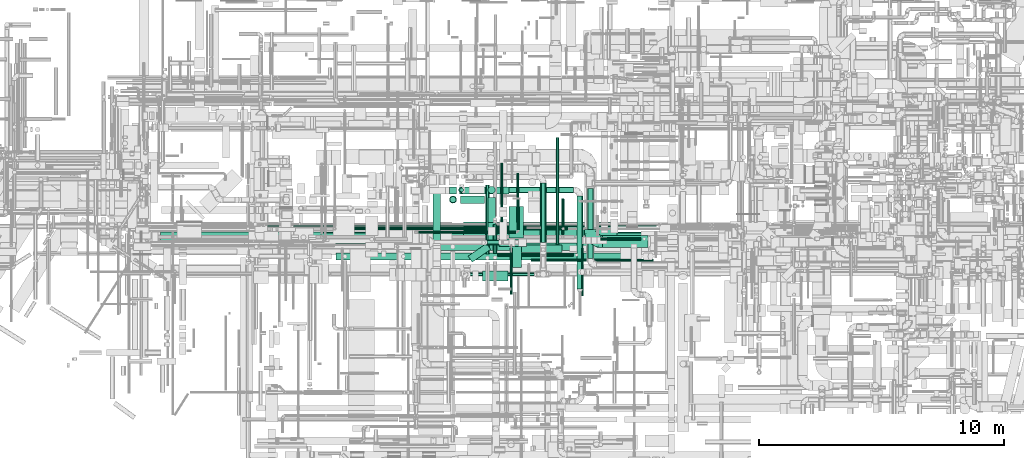
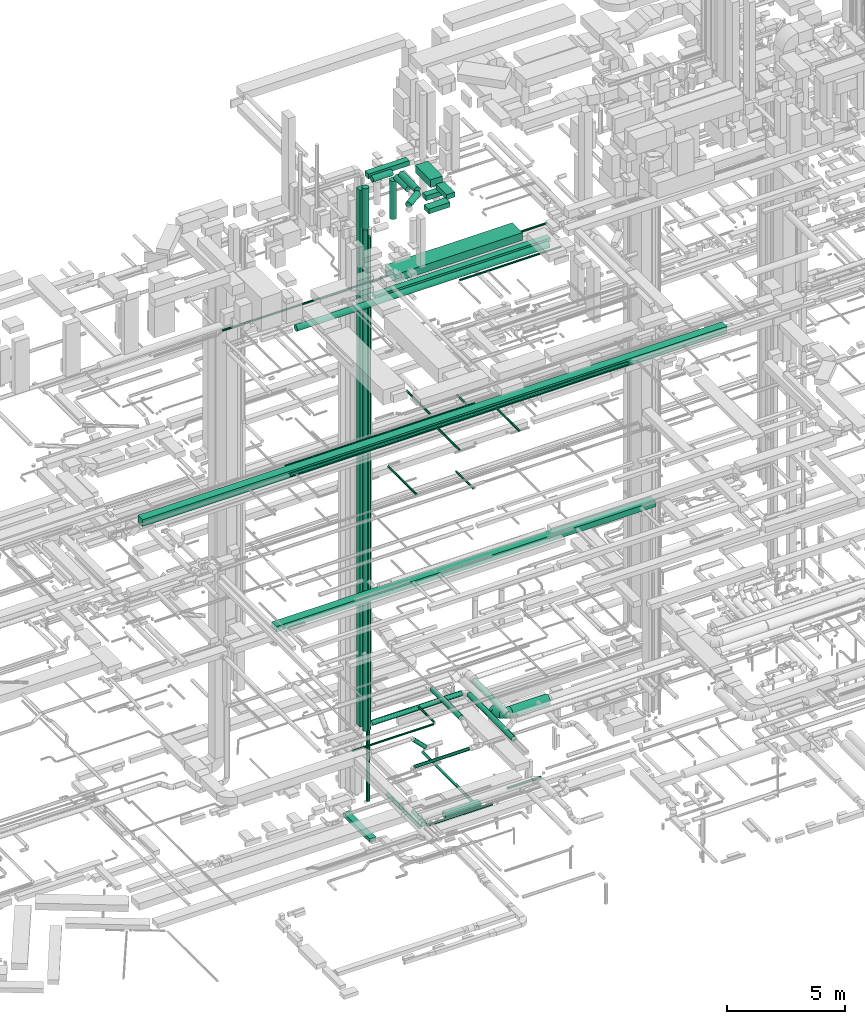
# One storey, part 33 of 337: 46 flow segments, 1 flow fitting.
"""IFC2X3 building model written with IfcOpenShell, lengths in millimetres."""

from ifc_helpers import new_model, entity, si_unit, converted_unit, derived_unit, direction, frame, origin, origin_2d_with_axis, place, context, subcontext, project, spatial, rectangle, circle, extrude, faceted_brep, source, transform, mapped, material, type_object, type_shapes, element, save


model = new_model("IFC2X3")

# Units and contexts
model_context = context("Model", 3, precision=0.01, world=origin(), true_north=direction((6.12303176911189e-17, 1.0)))
body_context = subcontext(model_context, "Body", "Model", "MODEL_VIEW")
ifc_project = project(units=[si_unit("LENGTHUNIT", "METRE", prefix="MILLI"), si_unit("AREAUNIT", "SQUARE_METRE"), si_unit("VOLUMEUNIT", "CUBIC_METRE"), converted_unit("PLANEANGLEUNIT", "DEGREE", entity("IfcRatioMeasure", 0.0174532925199433), si_unit("PLANEANGLEUNIT", "RADIAN"), dimensions=[0, 0, 0, 0, 0, 0, 0]), si_unit("MASSUNIT", "GRAM", prefix="KILO"), derived_unit("MASSDENSITYUNIT", [(si_unit("MASSUNIT", "GRAM", prefix="KILO"), 1), (si_unit("LENGTHUNIT", "METRE"), -3)]), derived_unit("MOMENTOFINERTIAUNIT", [(si_unit("LENGTHUNIT", "METRE"), 4)]), si_unit("TIMEUNIT", "SECOND"), si_unit("FREQUENCYUNIT", "HERTZ"), si_unit("THERMODYNAMICTEMPERATUREUNIT", "DEGREE_CELSIUS"), derived_unit("THERMALTRANSMITTANCEUNIT", [(si_unit("MASSUNIT", "GRAM", prefix="KILO"), 1), (si_unit("THERMODYNAMICTEMPERATUREUNIT", "KELVIN"), -1), (si_unit("TIMEUNIT", "SECOND"), -3)]), derived_unit("VOLUMETRICFLOWRATEUNIT", [(si_unit("LENGTHUNIT", "METRE"), 3), (si_unit("TIMEUNIT", "SECOND"), -1)]), derived_unit("MASSFLOWRATEUNIT", [(si_unit("MASSUNIT", "GRAM", prefix="KILO"), 1), (si_unit("TIMEUNIT", "SECOND"), -1)]), derived_unit("ROTATIONALFREQUENCYUNIT", [(si_unit("TIMEUNIT", "SECOND"), -1)]), si_unit("ELECTRICCURRENTUNIT", "AMPERE"), si_unit("ELECTRICVOLTAGEUNIT", "VOLT"), si_unit("POWERUNIT", "WATT"), si_unit("FORCEUNIT", "NEWTON", prefix="KILO"), si_unit("ILLUMINANCEUNIT", "LUX"), si_unit("LUMINOUSFLUXUNIT", "LUMEN"), si_unit("LUMINOUSINTENSITYUNIT", "CANDELA"), derived_unit("USERDEFINED", [(si_unit("MASSUNIT", "GRAM", prefix="KILO"), -1), (si_unit("LENGTHUNIT", "METRE"), -2), (si_unit("TIMEUNIT", "SECOND"), 3), (si_unit("LUMINOUSFLUXUNIT", "LUMEN"), 1)]), derived_unit("LINEARVELOCITYUNIT", [(si_unit("LENGTHUNIT", "METRE"), 1), (si_unit("TIMEUNIT", "SECOND"), -1)]), si_unit("PRESSUREUNIT", "PASCAL"), derived_unit("USERDEFINED", [(si_unit("LENGTHUNIT", "METRE"), -2), (si_unit("MASSUNIT", "GRAM", prefix="KILO"), 1), (si_unit("TIMEUNIT", "SECOND"), -2)]), derived_unit("LINEARFORCEUNIT", [(si_unit("MASSUNIT", "GRAM", prefix="KILO"), 1), (si_unit("LENGTHUNIT", "METRE"), 1), (si_unit("TIMEUNIT", "SECOND"), -2), (si_unit("LENGTHUNIT", "METRE"), -1)]), derived_unit("PLANARFORCEUNIT", [(si_unit("MASSUNIT", "GRAM", prefix="KILO"), 1), (si_unit("LENGTHUNIT", "METRE"), 1), (si_unit("TIMEUNIT", "SECOND"), -2), (si_unit("LENGTHUNIT", "METRE"), -2)])], contexts=[model_context])

# Site, building, storey
site_placement = place(None, origin())
site = spatial("IfcSite", under=ifc_project, at=site_placement, CompositionType="ELEMENT")
building_placement = place(site_placement, origin())
building = spatial("IfcBuilding", under=site, at=building_placement, CompositionType="ELEMENT")
storey_placement = place(building_placement, origin())
storey = spatial("IfcBuildingStorey", under=building, at=storey_placement, CompositionType="ELEMENT", Elevation=0.0)

# Flow segments
duct_segment_type_1 = type_object("IfcDuctSegmentType", PredefinedType="NOTDEFINED")
flow_segment_1_placement = place(storey_placement, frame((33827.72, 9095.01, -1025.0)))
element("IfcFlowSegment", 1, at=flow_segment_1_placement, inside=storey, type_object=duct_segment_type_1, context=body_context, shape_type="SweptSolid", body=[
    extrude(rectangle(XDim=1760.00000000005, YDim=300.0, at=origin_2d_with_axis()), frame((880.0, 150.0, 0.0), z_axis=(0.0, 0.0, 1.0), x_axis=(-1.0, 0.0, 0.0)), (0.0, 0.0, 1.0), 250.0),
])
flow_segment_2_placement = place(storey_placement, frame((30327.78, 9463.6, -1250.0)))
element("IfcFlowSegment", 2, at=flow_segment_2_placement, inside=storey, type_object=duct_segment_type_1, context=body_context, shape_type="SweptSolid", body=[
    extrude(rectangle(XDim=2274.44161305387, YDim=300.000000000001, at=origin_2d_with_axis()), frame((150.0, 1137.22, 0.0), z_axis=(0.0, 0.0, 1.0), x_axis=(0.0, -1.0, 0.0)), (0.0, 0.0, 1.0), 200.0),
])
flow_segment_3_placement = place(storey_placement, frame((25757.3, 9490.54, 11250.0)))
element("IfcFlowSegment", 3, at=flow_segment_3_placement, inside=storey, type_object=duct_segment_type_1, context=body_context, shape_type="SweptSolid", body=[
    extrude(rectangle(XDim=18609.9999999999, YDim=400.0, at=origin_2d_with_axis()), frame((9305.0, 200.0, 0.0), z_axis=(0.0, 0.0, 1.0), x_axis=(-1.0, 0.0, 0.0)), (0.0, 0.0, 1.0), 300.000000000001),
])
flow_segment_4_placement = place(storey_placement, frame((30990.08, 11464.96, 3300.0)))
element("IfcFlowSegment", 4, at=flow_segment_4_placement, inside=storey, type_object=duct_segment_type_1, context=body_context, shape_type="SweptSolid", body=[
    extrude(rectangle(XDim=300.000000000001, YDim=300.000000000001, at=origin_2d_with_axis()), frame((150.0, 150.0, 0.0)), (0.0, 0.0, 1.0), 27825.0000249999),
])
flow_segment_5_placement = place(storey_placement, frame((19213.85, 9525.31, 19000.0)))
element("IfcFlowSegment", 5, at=flow_segment_5_placement, inside=storey, type_object=duct_segment_type_1, context=body_context, shape_type="SweptSolid", body=[
    extrude(rectangle(XDim=28665.5634918612, YDim=400.0, at=origin_2d_with_axis()), frame((14332.78, 200.0, 0.0)), (0.0, 0.0, 1.0), 349.999999999998),
])
flow_segment_6_placement = place(storey_placement, frame((30433.85, 9174.41, 27050.0)))
element("IfcFlowSegment", 6, at=flow_segment_6_placement, inside=storey, type_object=duct_segment_type_1, context=body_context, shape_type="SweptSolid", body=[
    extrude(rectangle(XDim=8582.99999999966, YDim=300.0, at=origin_2d_with_axis()), frame((4291.5, 150.0, 0.0)), (0.0, 0.0, 1.0), 199.999999999998),
])
flow_segment_7_placement = place(storey_placement, frame((31576.8, 9489.97, 27350.0)))
element("IfcFlowSegment", 7, at=flow_segment_7_placement, inside=storey, type_object=duct_segment_type_1, context=body_context, shape_type="SweptSolid", body=[
    extrude(rectangle(XDim=6243.82128614733, YDim=850.000000000001, at=origin_2d_with_axis()), frame((3121.91, 425.0, 0.0), z_axis=(0.0, 0.0, 1.0), x_axis=(-1.0, 0.0, 0.0)), (0.0, 0.0, 1.0), 399.999999999996),
])
duct_segment_type_2 = type_object("IfcDuctSegmentType", PredefinedType="NOTDEFINED")
flow_segment_8_placement = place(storey_placement, frame((35335.54, 9415.01, -984.1)))
element("IfcFlowSegment", 8, at=flow_segment_8_placement, inside=storey, type_object=duct_segment_type_2, context=body_context, shape_type="SweptSolid", body=[
    extrude(circle(Radius=62.5, at=origin_2d_with_axis()), frame((64.1, 0.0, 64.1), z_axis=(0.0, 1.0, 0.0), x_axis=(1.0, 0.0, 0.0)), (0.0, 0.0, 1.0), 4352.10168621019),
])
flow_segment_9_placement = place(storey_placement, frame((32772.88, 9035.84, -1031.6)))
element("IfcFlowSegment", 9, at=flow_segment_9_placement, inside=storey, type_object=duct_segment_type_2, context=body_context, shape_type="SweptSolid", body=[
    extrude(circle(Radius=80.0, at=origin_2d_with_axis()), frame((81.6, 0.0, 81.6), z_axis=(0.0, 1.0, 0.0), x_axis=(-1.0, 0.0, 0.0)), (0.0, 0.0, 1.0), 1193.72583002033),
])
flow_segment_10_placement = place(storey_placement, frame((32954.47, 8925.87, -1014.1)))
element("IfcFlowSegment", 10, at=flow_segment_10_placement, inside=storey, type_object=duct_segment_type_2, context=body_context, shape_type="SweptSolid", body=[
    extrude(circle(Radius=62.5, at=origin_2d_with_axis()), frame((0.0, 64.1, 64.1), z_axis=(1.0, 0.0, 0.0), x_axis=(0.0, 1.0, 0.0)), (0.0, 0.0, 1.0), 3101.14743000002),
])
flow_segment_11_placement = place(storey_placement, frame((32462.52, 9021.92, -1031.6)))
element("IfcFlowSegment", 11, at=flow_segment_11_placement, inside=storey, type_object=duct_segment_type_2, context=body_context, shape_type="SweptSolid", body=[
    extrude(circle(Radius=80.0, at=origin_2d_with_axis()), frame((81.6, 0.0, 81.6), z_axis=(0.0, 1.0, 0.0), x_axis=(1.0, 0.0, 0.0)), (0.0, 0.0, 1.0), 2819.49726000001),
])
flow_segment_12_placement = place(storey_placement, frame((32401.82, 9397.48, 2686.27)))
element("IfcFlowSegment", 12, at=flow_segment_12_placement, inside=storey, type_object=duct_segment_type_2, context=body_context, shape_type="SweptSolid", body=[
    extrude(circle(Radius=100.0, at=origin_2d_with_axis()), frame((72.31, 101.6, 655.15), z_axis=(0.707106781186538, 0.0, -0.707106781186557), x_axis=(0.0, -1.0, 0.0)), (0.0, 0.0, 1.0), 824.264068711905),
])
flow_segment_13_placement = place(storey_placement, frame((33750.69, 10012.65, 3398.4)))
element("IfcFlowSegment", 13, at=flow_segment_13_placement, inside=storey, type_object=duct_segment_type_2, context=body_context, shape_type="SweptSolid", body=[
    extrude(circle(Radius=50.0, at=origin_2d_with_axis()), frame((51.6, 0.0, 51.6), z_axis=(0.0, 1.0, 0.0), x_axis=(1.0, 0.0, 0.0)), (0.0, 0.0, 1.0), 1300.00000000001),
])
flow_segment_14_placement = place(storey_placement, frame((36617.96, 8836.67, 3423.4)))
element("IfcFlowSegment", 14, at=flow_segment_14_placement, inside=storey, type_object=duct_segment_type_2, context=body_context, shape_type="SweptSolid", body=[
    extrude(circle(Radius=125.0, at=origin_2d_with_axis()), frame((126.6, 0.0, 126.6), z_axis=(0.0, 1.0, 0.0), x_axis=(1.0, 0.0, 0.0)), (0.0, 0.0, 1.0), 2863.31900942015),
])
flow_segment_15_placement = place(storey_placement, frame((31635.77, 11508.82, 3053.4)))
element("IfcFlowSegment", 15, at=flow_segment_15_placement, inside=storey, type_object=duct_segment_type_2, context=body_context, shape_type="SweptSolid", body=[
    extrude(circle(Radius=125.0, at=origin_2d_with_axis()), frame((0.0, 126.6, 126.6), z_axis=(1.0, 0.0, 0.0), x_axis=(0.0, 1.0, 0.0)), (0.0, 0.0, 1.0), 4428.12898502816),
])
flow_segment_16_placement = place(storey_placement, frame((31409.18, 11555.81, -790.0)))
element("IfcFlowSegment", 16, at=flow_segment_16_placement, inside=storey, type_object=duct_segment_type_2, context=body_context, shape_type="SweptSolid", body=[
    extrude(circle(Radius=80.0, at=origin_2d_with_axis()), frame((81.6, 81.6, 0.0), z_axis=(0.0, 0.0, 1.0), x_axis=(-1.0, 0.0, 0.0)), (0.0, 0.0, 1.0), 3624.99999999998),
])
flow_segment_17_placement = place(storey_placement, frame((31364.18, 11510.81, 2925.0)))
element("IfcFlowSegment", 17, at=flow_segment_17_placement, inside=storey, type_object=duct_segment_type_2, context=body_context, shape_type="SweptSolid", body=[
    extrude(circle(Radius=125.0, at=origin_2d_with_axis()), frame((126.6, 126.6, 0.0), z_axis=(0.0, 0.0, 1.0), x_axis=(-1.0, 0.0, 0.0)), (0.0, 0.0, 1.0), 25545.000025),
])
flow_segment_18_placement = place(storey_placement, frame((31013.4, 11117.9, 3250.0)))
element("IfcFlowSegment", 18, at=flow_segment_18_placement, inside=storey, type_object=duct_segment_type_2, context=body_context, shape_type="SweptSolid", body=[
    extrude(circle(Radius=125.0, at=origin_2d_with_axis()), frame((126.6, 126.6, 0.0), z_axis=(0.0, 0.0, 1.0), x_axis=(0.0, 1.0, 0.0)), (0.0, 0.0, 1.0), 25996.0314619003),
])
flow_segment_19_placement = place(storey_placement, frame((34693.82, 9484.38, 3523.4)))
element("IfcFlowSegment", 19, at=flow_segment_19_placement, inside=storey, type_object=duct_segment_type_2, context=body_context, shape_type="SweptSolid", body=[
    extrude(circle(Radius=125.0, at=origin_2d_with_axis()), frame((126.6, 0.0, 126.6), z_axis=(0.0, 1.0, 0.0), x_axis=(-1.0, 0.0, 0.0)), (0.0, 0.0, 1.0), 2444.2715571516),
])
flow_segment_20_placement = place(storey_placement, frame((31762.03, 8118.43, 2868.4)))
element("IfcFlowSegment", 20, at=flow_segment_20_placement, inside=storey, type_object=duct_segment_type_2, context=body_context, shape_type="SweptSolid", body=[
    extrude(circle(Radius=80.0, at=origin_2d_with_axis()), frame((0.0, 81.6, 81.6), z_axis=(1.0, 0.0, 0.0), x_axis=(0.0, 1.0, 0.0)), (0.0, 0.0, 1.0), 2696.875),
])
flow_segment_21_placement = place(storey_placement, frame((37244.56, 9280.9, 2828.4)))
element("IfcFlowSegment", 21, at=flow_segment_21_placement, inside=storey, type_object=duct_segment_type_2, context=body_context, shape_type="SweptSolid", body=[
    extrude(circle(Radius=250.0, at=origin_2d_with_axis()), frame((0.0, 251.6, 251.6), z_axis=(1.0, 0.0, 0.0), x_axis=(0.0, 0.0, 1.0)), (0.0, 0.0, 1.0), 1844.58528176817),
])
flow_segment_22_placement = place(storey_placement, frame((26504.69, 9993.02, 19185.9)))
element("IfcFlowSegment", 22, at=flow_segment_22_placement, inside=storey, type_object=duct_segment_type_2, context=body_context, shape_type="SweptSolid", body=[
    extrude(circle(Radius=62.5, at=origin_2d_with_axis()), frame((0.0, 64.1, 64.1), z_axis=(1.0, 0.0, 0.0), x_axis=(0.0, -1.0, 0.0)), (0.0, 0.0, 1.0), 9297.81249999997),
])
flow_segment_23_placement = place(storey_placement, frame((35581.06, 10157.12, 18988.4)))
element("IfcFlowSegment", 23, at=flow_segment_23_placement, inside=storey, type_object=duct_segment_type_2, context=body_context, shape_type="SweptSolid", body=[
    extrude(circle(Radius=50.0, at=origin_2d_with_axis()), frame((51.6, 0.0, 51.6), z_axis=(0.0, 1.0, 0.0), x_axis=(1.0, 0.0, 0.0)), (0.0, 0.0, 1.0), 1102.49999999999),
])
flow_segment_24_placement = place(storey_placement, frame((33731.01, 10319.9, 19198.4)))
element("IfcFlowSegment", 24, at=flow_segment_24_placement, inside=storey, type_object=duct_segment_type_2, context=body_context, shape_type="SweptSolid", body=[
    extrude(circle(Radius=50.0, at=origin_2d_with_axis()), frame((51.6, 0.0, 51.6), z_axis=(0.0, 1.0, 0.0), x_axis=(1.0, 0.0, 0.0)), (0.0, 0.0, 1.0), 2004.99999999991),
])
flow_segment_25_placement = place(storey_placement, frame((36369.72, 7318.31, 19223.4)))
element("IfcFlowSegment", 25, at=flow_segment_25_placement, inside=storey, type_object=duct_segment_type_2, context=body_context, shape_type="SweptSolid", body=[
    extrude(circle(Radius=50.0, at=origin_2d_with_axis()), frame((51.6, 0.0, 51.6), z_axis=(0.0, 1.0, 0.0), x_axis=(-1.0, 0.0, 0.0)), (0.0, 0.0, 1.0), 1951.81449716544),
])
flow_segment_26_placement = place(storey_placement, frame((33468.19, 7368.95, 19223.4)))
element("IfcFlowSegment", 26, at=flow_segment_26_placement, inside=storey, type_object=duct_segment_type_2, context=body_context, shape_type="SweptSolid", body=[
    extrude(circle(Radius=50.0, at=origin_2d_with_axis()), frame((51.6, 0.0, 51.6), z_axis=(0.0, 1.0, 0.0), x_axis=(-1.0, 0.0, 0.0)), (0.0, 0.0, 1.0), 1901.16812135757),
])
flow_segment_27_placement = place(storey_placement, frame((26349.84, 9288.52, 19193.4)))
element("IfcFlowSegment", 27, at=flow_segment_27_placement, inside=storey, type_object=duct_segment_type_2, context=body_context, shape_type="SweptSolid", body=[
    extrude(circle(Radius=80.0, at=origin_2d_with_axis()), frame((0.0, 81.6, 81.6), z_axis=(1.0, 0.0, 0.0), x_axis=(0.0, -1.0, 0.0)), (0.0, 0.0, 1.0), 16599.9999999999),
])
flow_segment_28_placement = place(storey_placement, frame((35564.72, 9815.69, 14998.4)))
element("IfcFlowSegment", 28, at=flow_segment_28_placement, inside=storey, type_object=duct_segment_type_2, context=body_context, shape_type="SweptSolid", body=[
    extrude(circle(Radius=50.0, at=origin_2d_with_axis()), frame((51.6, 0.0, 51.6), z_axis=(0.0, 1.0, 0.0), x_axis=(1.0, 0.0, 0.0)), (0.0, 0.0, 1.0), 1478.23637793733),
])
flow_segment_29_placement = place(storey_placement, frame((33070.57, 10328.79, 15248.4)))
element("IfcFlowSegment", 29, at=flow_segment_29_placement, inside=storey, type_object=duct_segment_type_2, context=body_context, shape_type="SweptSolid", body=[
    extrude(circle(Radius=50.0, at=origin_2d_with_axis()), frame((51.6, 0.0, 51.6), z_axis=(0.0, 1.0, 0.0), x_axis=(-1.0, 0.0, 0.0)), (0.0, 0.0, 1.0), 2405.52097325717),
])
flow_segment_30_placement = place(storey_placement, frame((26376.92, 8773.38, 26998.4)))
element("IfcFlowSegment", 30, at=flow_segment_30_placement, inside=storey, type_object=duct_segment_type_2, context=body_context, shape_type="SweptSolid", body=[
    extrude(circle(Radius=150.0, at=origin_2d_with_axis()), frame((0.0, 151.6, 151.6), z_axis=(1.0, 0.0, 0.0), x_axis=(0.0, -1.0, 0.0)), (0.0, 0.0, 1.0), 12391.6097205523),
])
flow_segment_31_placement = place(storey_placement, frame((32568.4, 9581.59, 31548.4)))
element("IfcFlowSegment", 31, at=flow_segment_31_placement, inside=storey, type_object=duct_segment_type_2, context=body_context, shape_type="SweptSolid", body=[
    extrude(circle(Radius=150.0, at=origin_2d_with_axis()), frame((151.6, 0.0, 151.6), z_axis=(0.0, 1.0, 0.0), x_axis=(-1.0, 0.0, 0.0)), (0.0, 0.0, 1.0), 1362.912496586),
])
flow_segment_32_placement = place(storey_placement, frame((31440.0, 11092.9, 31548.4)))
element("IfcFlowSegment", 32, at=flow_segment_32_placement, inside=storey, type_object=duct_segment_type_2, context=body_context, shape_type="SweptSolid", body=[
    extrude(circle(Radius=150.0, at=origin_2d_with_axis()), frame((0.0, 151.6, 151.6), z_axis=(1.0, 0.0, 0.0), x_axis=(0.0, 1.0, 0.0)), (0.0, 0.0, 1.0), 980.000306854162),
])
flow_segment_33_placement = place(storey_placement, frame((30988.4, 11092.9, 29296.03)))
element("IfcFlowSegment", 33, at=flow_segment_33_placement, inside=storey, type_object=duct_segment_type_2, context=body_context, shape_type="SweptSolid", body=[
    extrude(circle(Radius=150.0, at=origin_2d_with_axis()), frame((151.6, 151.6, 0.0), z_axis=(0.0, 0.0, 1.0), x_axis=(0.0, -1.0, 0.0)), (0.0, 0.0, 1.0), 2103.96853809967),
])
flow_segment_34_placement = place(storey_placement, frame((32564.1, 10317.62, 31148.4)))
element("IfcFlowSegment", 34, at=flow_segment_34_placement, inside=storey, type_object=duct_segment_type_2, context=body_context, shape_type="SweptSolid", body=[
    extrude(circle(Radius=150.0, at=origin_2d_with_axis()), frame((151.6, 0.0, 151.6), z_axis=(0.0, 1.0, 0.0), x_axis=(1.0, 0.0, 0.0)), (0.0, 0.0, 1.0), 1019.78961208377),
])
flow_segment_35_placement = place(storey_placement, frame((32564.1, 11485.81, 29020.0)))
element("IfcFlowSegment", 35, at=flow_segment_35_placement, inside=storey, type_object=duct_segment_type_2, context=body_context, shape_type="SweptSolid", body=[
    extrude(circle(Radius=150.0, at=origin_2d_with_axis()), frame((151.6, 151.6, 0.0), z_axis=(0.0, 0.0, 1.0), x_axis=(-1.0, 0.0, 0.0)), (0.0, 0.0, 1.0), 1980.00000000001),
])
flow_segment_36_placement = place(storey_placement, frame((34325.67, 8713.04, 26898.4)))
element("IfcFlowSegment", 36, at=flow_segment_36_placement, inside=storey, type_object=duct_segment_type_2, context=body_context, shape_type="SweptSolid", body=[
    extrude(circle(Radius=50.0, at=origin_2d_with_axis()), frame((0.0, 51.6, 51.6), z_axis=(1.0, 0.0, 0.0), x_axis=(0.0, 1.0, 0.0)), (0.0, 0.0, 1.0), 4991.39999999997),
])
flow_segment_37_placement = place(storey_placement, frame((23527.87, 10148.35, 27198.4)))
element("IfcFlowSegment", 37, at=flow_segment_37_placement, inside=storey, type_object=duct_segment_type_2, context=body_context, shape_type="SweptSolid", body=[
    extrude(circle(Radius=50.0, at=origin_2d_with_axis()), frame((0.0, 51.6, 51.6), z_axis=(1.0, 0.0, 0.0), x_axis=(0.0, 1.0, 0.0)), (0.0, 0.0, 1.0), 15908.9372875249),
])
flow_segment_38_placement = place(storey_placement, frame((29724.24, 9861.05, 3398.4)))
element("IfcFlowSegment", 38, at=flow_segment_38_placement, inside=storey, type_object=duct_segment_type_2, context=body_context, shape_type="SweptSolid", body=[
    extrude(circle(Radius=50.0, at=origin_2d_with_axis()), frame((0.0, 51.6, 51.6), z_axis=(1.0, 0.0, 0.0), x_axis=(0.0, 1.0, 0.0)), (0.0, 0.0, 1.0), 3978.04468868716),
])
flow_segment_39_placement = place(storey_placement, frame((36187.31, 7600.0, 3053.4)))
element("IfcFlowSegment", 39, at=flow_segment_39_placement, inside=storey, type_object=duct_segment_type_2, context=body_context, shape_type="SweptSolid", body=[
    extrude(circle(Radius=125.0, at=origin_2d_with_axis()), frame((126.6, 0.0, 126.6), z_axis=(0.0, 1.0, 0.0), x_axis=(-1.0, 0.0, 0.0)), (0.0, 0.0, 1.0), 3785.42103364382),
])
flow_segment_40_placement = place(storey_placement, frame((31752.07, 8689.1, 31548.4)))
element("IfcFlowSegment", 40, at=flow_segment_40_placement, inside=storey, type_object=duct_segment_type_2, context=body_context, shape_type="SweptSolid", body=[
    extrude(circle(Radius=150.0, at=origin_2d_with_axis()), frame((87.04, 124.88, 151.6), z_axis=(0.821899128606518, 0.569633059430233, 0.0), x_axis=(-0.569633059430233, 0.821899128606518, 0.0)), (0.0, 0.0, 1.0), 914.686254665838),
])
flow_segment_41_placement = place(storey_placement, frame((37158.02, 9579.05, -984.1)))
element("IfcFlowSegment", 41, at=flow_segment_41_placement, inside=storey, type_object=duct_segment_type_2, context=body_context, shape_type="SweptSolid", body=[
    extrude(circle(Radius=62.5, at=origin_2d_with_axis()), frame((0.0, 64.1, 64.1), z_axis=(1.0, 0.0, 0.0), x_axis=(0.0, 1.0, 0.0)), (0.0, 0.0, 1.0), 1656.78869999999),
])
duct_segment_type_3 = type_object("IfcDuctSegmentType", PredefinedType="NOTDEFINED")
flow_segment_42_placement = place(storey_placement, frame((33525.03, 8484.51, 31575.0)))
element("IfcFlowSegment", 42, at=flow_segment_42_placement, inside=storey, type_object=duct_segment_type_3, context=body_context, shape_type="SweptSolid", body=[
    extrude(rectangle(XDim=901.21811497607, YDim=400.0, at=origin_2d_with_axis()), frame((200.0, 450.61, 0.0), z_axis=(0.0, 0.0, 1.0), x_axis=(0.0, 1.0, 0.0)), (0.0, 0.0, 1.0), 250.000000000004),
])
flow_segment_43_placement = place(storey_placement, frame((33425.03, 9685.73, 31500.0)))
element("IfcFlowSegment", 43, at=flow_segment_43_placement, inside=storey, type_object=duct_segment_type_3, context=body_context, shape_type="SweptSolid", body=[
    extrude(rectangle(XDim=1280.00000000011, YDim=600.000000000002, at=origin_2d_with_axis()), frame((300.0, 640.0, 0.0), z_axis=(0.0, 0.0, 1.0), x_axis=(0.0, 1.0, 0.0)), (0.0, 0.0, 1.0), 399.999999999996),
])
flow_segment_44_placement = place(storey_placement, frame((31415.08, 11464.96, 31575.0)))
element("IfcFlowSegment", 44, at=flow_segment_44_placement, inside=storey, type_object=duct_segment_type_3, context=body_context, shape_type="SweptSolid", body=[
    extrude(rectangle(XDim=2009.95411000001, YDim=300.000000000001, at=origin_2d_with_axis()), frame((1004.98, 150.0, 0.0), z_axis=(0.0, 0.0, 1.0), x_axis=(-1.0, 0.0, 0.0)), (0.0, 0.0, 1.0), 250.000000000004),
])
flow_segment_45_placement = place(storey_placement, frame((33015.69, 9332.41, 31175.0)))
element("IfcFlowSegment", 45, at=flow_segment_45_placement, inside=storey, type_object=duct_segment_type_3, context=body_context, shape_type="SweptSolid", body=[
    extrude(rectangle(XDim=1130.29030211878, YDim=300.0, at=origin_2d_with_axis()), frame((565.15, 150.0, 0.0), z_axis=(0.0, 0.0, 1.0), x_axis=(-1.0, 0.0, 0.0)), (0.0, 0.0, 1.0), 250.000000000004),
])
flow_segment_46_placement = place(storey_placement, frame((32334.5, 7934.51, 31575.0)))
element("IfcFlowSegment", 46, at=flow_segment_46_placement, inside=storey, type_object=duct_segment_type_3, context=body_context, shape_type="SweptSolid", body=[
    extrude(rectangle(XDim=1040.53326780526, YDim=400.0, at=origin_2d_with_axis()), frame((520.27, 200.0, 0.0), z_axis=(0.0, 0.0, 1.0), x_axis=(-1.0, 0.0, 0.0)), (0.0, 0.0, 1.0), 250.000000000004),
])

# Flow fitting
ifc_material = material()
duct_fitting_type = type_object("IfcDuctFittingType", PredefinedType="NOTDEFINED", material=ifc_material)
shared_shape = source(origin(), body_context, "Body", "Brep", [
    faceted_brep([(-500.0, 0.0, -250.0), (-500.0, -55.63, -243.73), (-500.0, -108.47, -225.24), (-500.0, -155.87, -195.46), (-500.0, -195.46, -155.87), (-500.0, -225.24, -108.47), (-500.0, -243.73, -55.63), (-500.0, -250.0, 0.0), (-500.0, -243.73, 55.63), (-500.0, -225.24, 108.47), (-500.0, -195.46, 155.87), (-500.0, -155.87, 195.46), (-500.0, -108.47, 225.24), (-500.0, -55.63, 243.73), (-500.0, 0.0, 250.0), (-500.0, 55.63, 243.73), (-500.0, 108.47, 225.24), (-500.0, 155.87, 195.46), (-500.0, 195.46, 155.87), (-500.0, 225.24, 108.47), (-500.0, 243.73, 55.63), (-500.0, 250.0, 0.0), (-500.0, 243.73, -55.63), (-500.0, 225.24, -108.47), (-500.0, 195.46, -155.87), (-500.0, 155.87, -195.46), (-500.0, 108.47, -225.24), (-500.0, 55.63, -243.73), (-366.03, 0.0, 250.0), (-379.09, 48.77, 245.2), (-391.66, 95.67, 230.97), (-403.24, 138.89, 207.87), (-413.39, 176.78, 176.78), (-421.72, 207.87, 138.89), (-427.91, 230.97, 95.67), (-431.73, 245.2, 48.77), (-433.01, 250.0, 0.0), (-431.73, 245.2, -48.77), (-427.91, 230.97, -95.67), (-421.72, 207.87, -138.89), (-413.39, 176.78, -176.78), (-403.24, 138.89, -207.87), (-391.66, 95.67, -230.97), (-379.09, 48.77, -245.2), (-366.03, 0.0, -250.0), (-352.96, -48.77, -245.2), (-340.39, -95.67, -230.97), (-328.81, -138.89, -207.87), (-318.66, -176.78, -176.78), (-310.33, -207.87, -138.89), (-304.14, -230.97, -95.67), (-300.33, -245.2, -48.77), (-299.04, -250.0, 0.0), (-300.33, -245.2, 48.77), (-304.14, -230.97, 95.67), (-310.33, -207.87, 138.89), (-318.66, -176.78, 176.78), (-328.81, -138.89, 207.87), (-340.39, -95.67, 230.97), (-352.96, -48.77, 245.2), (-133.97, 133.97, 250.0), (-169.68, 169.68, 245.2), (-204.01, 204.01, 230.97), (-235.65, 235.65, 207.87), (-263.38, 263.38, 176.78), (-286.14, 286.14, 138.89), (-303.06, 303.06, 95.67), (-313.47, 313.47, 48.77), (-316.99, 316.99, 0.0), (-313.47, 313.47, -48.77), (-303.06, 303.06, -95.67), (-286.14, 286.14, -138.89), (-263.38, 263.38, -176.78), (-235.65, 235.65, -207.87), (-204.01, 204.01, -230.97), (-169.68, 169.68, -245.2), (-133.97, 133.97, -250.0), (-98.27, 98.27, -245.2), (-63.94, 63.94, -230.97), (-32.3, 32.3, -207.87), (-4.57, 4.57, -176.78), (18.19, -18.19, -138.89), (35.11, -35.11, -95.67), (45.52, -45.52, -48.77), (49.04, -49.04, 0.0), (45.52, -45.52, 48.77), (35.11, -35.11, 95.67), (18.19, -18.19, 138.89), (-4.57, 4.57, 176.78), (-32.3, 32.3, 207.87), (-63.94, 63.94, 230.97), (-98.27, 98.27, 245.2), (0.0, 366.03, 250.0), (-48.77, 379.09, 245.2), (-95.67, 391.66, 230.97), (-138.89, 403.24, 207.87), (-176.78, 413.39, 176.78), (-207.87, 421.72, 138.89), (-230.97, 427.91, 95.67), (-245.2, 431.73, 48.77), (-250.0, 433.01, 0.0), (-245.2, 431.73, -48.77), (-230.97, 427.91, -95.67), (-207.87, 421.72, -138.89), (-176.78, 413.39, -176.78), (-138.89, 403.24, -207.87), (-95.67, 391.66, -230.97), (-48.77, 379.09, -245.2), (0.0, 366.03, -250.0), (48.77, 352.96, -245.2), (95.67, 340.39, -230.97), (138.89, 328.81, -207.87), (176.78, 318.66, -176.78), (207.87, 310.33, -138.89), (230.97, 304.14, -95.67), (245.2, 300.33, -48.77), (250.0, 299.04, 0.0), (245.2, 300.33, 48.77), (230.97, 304.14, 95.67), (207.87, 310.33, 138.89), (176.78, 318.66, 176.78), (138.89, 328.81, 207.87), (95.67, 340.39, 230.97), (48.77, 352.96, 245.2), (0.0, 500.0, -250.0), (-55.63, 500.0, -243.73), (-108.47, 500.0, -225.24), (-155.87, 500.0, -195.46), (-195.46, 500.0, -155.87), (-225.24, 500.0, -108.47), (-243.73, 500.0, -55.63), (-250.0, 500.0, 0.0), (-243.73, 500.0, 55.63), (-225.24, 500.0, 108.47), (-195.46, 500.0, 155.87), (-155.87, 500.0, 195.46), (-108.47, 500.0, 225.24), (-55.63, 500.0, 243.73), (0.0, 500.0, 250.0), (55.63, 500.0, 243.73), (108.47, 500.0, 225.24), (155.87, 500.0, 195.46), (195.46, 500.0, 155.87), (225.24, 500.0, 108.47), (243.73, 500.0, 55.63), (250.0, 500.0, 0.0), (243.73, 500.0, -55.63), (225.24, 500.0, -108.47), (195.46, 500.0, -155.87), (155.87, 500.0, -195.46), (108.47, 500.0, -225.24), (55.63, 500.0, -243.73)], [[[0, 1, 2, 3, 4, 5, 6, 7, 8, 9, 10, 11, 12, 13, 14, 15, 16, 17, 18, 19, 20, 21, 22, 23, 24, 25, 26, 27]], [[28, 29, 14]], [[30, 31, 16]], [[29, 30, 15]], [[14, 29, 15]], [[15, 30, 16]], [[31, 17, 16]], [[31, 32, 17]], [[32, 33, 18]], [[34, 35, 20]], [[33, 34, 19]], [[18, 33, 19]], [[35, 21, 20]], [[20, 19, 34]], [[21, 35, 36]], [[32, 18, 17]], [[36, 37, 21]], [[38, 39, 23]], [[37, 38, 22]], [[21, 37, 22]], [[24, 23, 39]], [[38, 23, 22]], [[39, 40, 24]], [[41, 42, 26]], [[43, 44, 0]], [[42, 43, 27]], [[40, 25, 24]], [[40, 41, 25]], [[26, 25, 41]], [[42, 27, 26]], [[43, 0, 27]], [[1, 44, 45]], [[45, 46, 1]], [[47, 2, 46]], [[0, 44, 1]], [[1, 46, 2]], [[47, 3, 2]], [[47, 48, 3]], [[5, 49, 50]], [[50, 51, 6]], [[52, 7, 51]], [[48, 4, 3]], [[48, 49, 4]], [[5, 4, 49]], [[50, 6, 5]], [[51, 7, 6]], [[7, 52, 53]], [[8, 53, 54]], [[9, 54, 55]], [[7, 53, 8]], [[8, 54, 9]], [[55, 10, 9]], [[55, 56, 10]], [[11, 56, 57]], [[12, 57, 58]], [[13, 58, 59]], [[11, 57, 12]], [[13, 28, 14]], [[13, 12, 58]], [[28, 13, 59]], [[56, 11, 10]], [[60, 61, 29, 28]], [[62, 63, 31, 30]], [[61, 62, 30, 29]], [[32, 31, 63, 64]], [[64, 65, 33, 32]], [[66, 67, 35, 34]], [[65, 66, 34, 33]], [[67, 68, 36, 35]], [[68, 69, 37, 36]], [[70, 71, 39, 38]], [[69, 70, 38, 37]], [[40, 39, 71, 72]], [[73, 74, 42, 41]], [[75, 76, 44, 43]], [[74, 75, 43, 42]], [[72, 73, 41, 40]], [[45, 44, 76, 77]], [[77, 78, 46, 45]], [[79, 47, 46, 78]], [[47, 79, 80, 48]], [[50, 49, 81, 82]], [[82, 83, 51, 50]], [[84, 52, 51, 83]], [[80, 81, 49, 48]], [[53, 52, 84, 85]], [[54, 53, 85, 86]], [[55, 54, 86, 87]], [[87, 88, 56, 55]], [[57, 56, 88, 89]], [[58, 57, 89, 90]], [[59, 58, 90, 91]], [[91, 60, 28, 59]], [[92, 93, 61, 60]], [[94, 95, 63, 62]], [[93, 94, 62, 61]], [[64, 63, 95, 96]], [[96, 97, 65, 64]], [[98, 99, 67, 66]], [[97, 98, 66, 65]], [[99, 100, 68, 67]], [[100, 101, 69, 68]], [[102, 103, 71, 70]], [[101, 102, 70, 69]], [[72, 71, 103, 104]], [[105, 106, 74, 73]], [[107, 108, 76, 75]], [[106, 107, 75, 74]], [[104, 105, 73, 72]], [[77, 76, 108, 109]], [[109, 110, 78, 77]], [[111, 79, 78, 110]], [[79, 111, 112, 80]], [[82, 81, 113, 114]], [[114, 115, 83, 82]], [[116, 84, 83, 115]], [[112, 113, 81, 80]], [[85, 84, 116, 117]], [[86, 85, 117, 118]], [[87, 86, 118, 119]], [[119, 120, 88, 87]], [[89, 88, 120, 121]], [[90, 89, 121, 122]], [[91, 90, 122, 123]], [[123, 92, 60, 91]], [[124, 125, 126, 127, 128, 129, 130, 131, 132, 133, 134, 135, 136, 137, 138, 139, 140, 141, 142, 143, 144, 145, 146, 147, 148, 149, 150, 151]], [[93, 138, 137]], [[94, 137, 136]], [[95, 136, 135]], [[93, 92, 138]], [[95, 94, 136]], [[93, 137, 94]], [[135, 96, 95]], [[97, 134, 133]], [[98, 133, 132]], [[99, 132, 131]], [[97, 96, 134]], [[99, 98, 132]], [[100, 99, 131]], [[97, 133, 98]], [[134, 96, 135]], [[101, 131, 130]], [[129, 128, 103]], [[102, 130, 129]], [[101, 100, 131]], [[103, 102, 129]], [[101, 130, 102]], [[128, 104, 103]], [[105, 127, 126]], [[106, 126, 125]], [[107, 125, 124]], [[105, 104, 127]], [[107, 106, 125]], [[108, 107, 124]], [[105, 126, 106]], [[127, 104, 128]], [[108, 124, 151]], [[110, 151, 150]], [[111, 150, 149]], [[108, 151, 109]], [[110, 109, 151]], [[111, 110, 150]], [[149, 112, 111]], [[113, 148, 147]], [[114, 147, 146]], [[115, 146, 145]], [[112, 148, 113]], [[146, 115, 114]], [[114, 113, 147]], [[115, 145, 116]], [[148, 112, 149]], [[117, 145, 144]], [[118, 144, 143]], [[119, 143, 142]], [[116, 145, 117]], [[117, 144, 118]], [[143, 119, 118]], [[142, 120, 119]], [[121, 141, 140]], [[122, 140, 139]], [[92, 139, 138]], [[120, 141, 121]], [[122, 121, 140]], [[139, 123, 122]], [[139, 92, 123]], [[141, 120, 142]]]),
])
type_shapes(duct_fitting_type, [shared_shape])
flow_fitting_placement = place(storey_placement, frame((36744.56, 9532.5, 3080.0), z_axis=(0.0, 0.0, 1.0), x_axis=(0.0, -1.0, 0.0)))
element("IfcFlowFitting", 47, at=flow_fitting_placement, inside=storey, type_object=duct_fitting_type, material=ifc_material, context=body_context, shape_type="MappedRepresentation", body=[
    mapped(shared_shape, transform((0.0, 0.0, 0.0), scale=1.0)),
])

save(model, "model.ifc")
